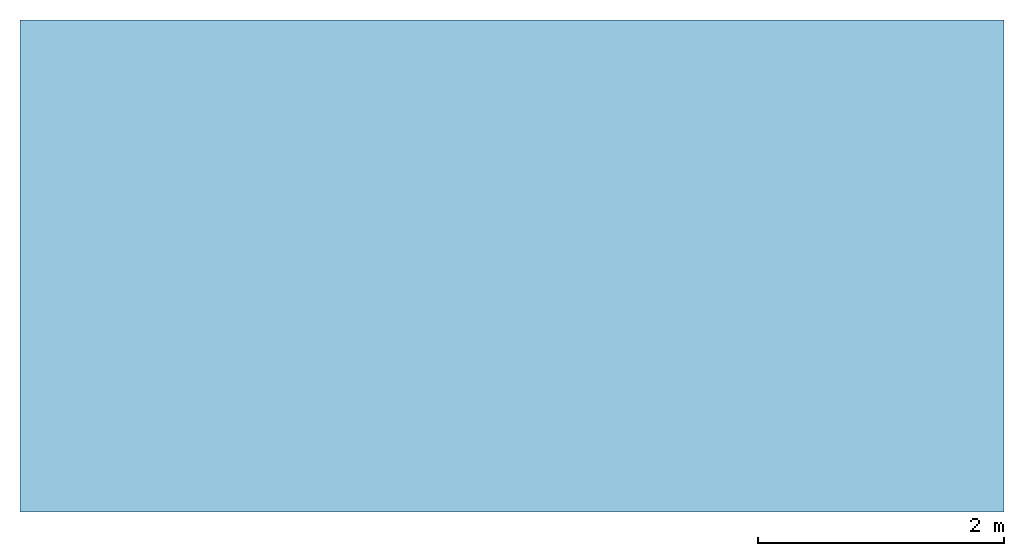
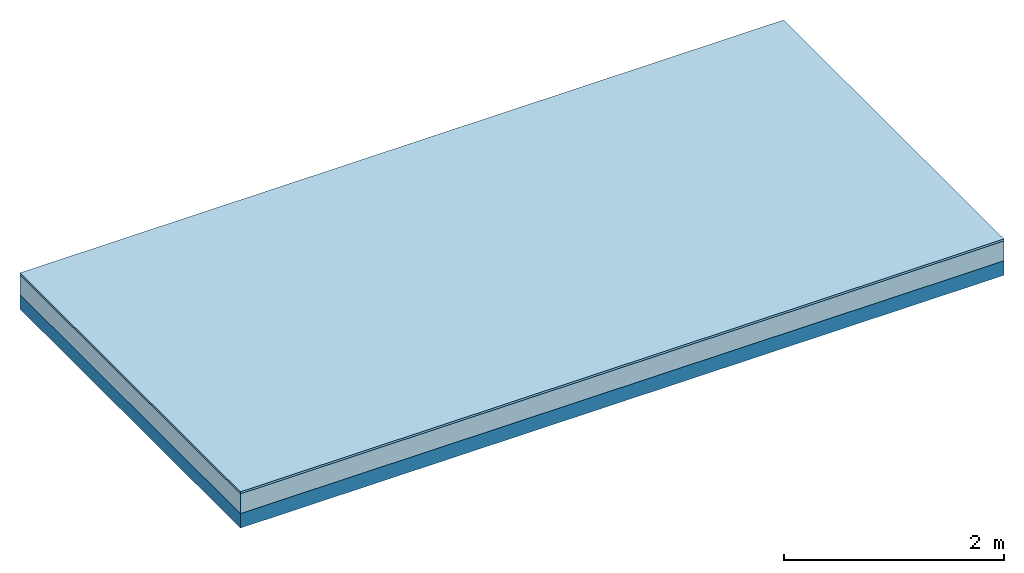
# One storey: 2 plates, 1 member, 1 element without a shape of its own.
"""IFC4 building model written with IfcOpenShell, lengths in metres."""

from ifc_helpers import new_model, si_unit, derived_unit, direction, frame, frame_2d, origin, origin_with_axes, place, context, project, spatial, rectangle, extrude, material, layer, layer_set, type_object, element, aggregate, save


model = new_model("IFC4")

# Units and contexts
plan_context = context("Plan", 3, precision=1e-05, world=origin(), true_north=direction((0.0, 1.0)))
model_context = context("Model", 3, precision=1e-05, world=origin(), true_north=direction((0.0, 1.0)))
ifc_project = project(units=[si_unit("LENGTHUNIT", "METRE"), derived_unit("SOUNDPRESSUREUNIT", [(si_unit("PRESSUREUNIT", "PASCAL", prefix="MICRO"), 0)]), si_unit("ENERGYUNIT", "JOULE", prefix="MEGA"), si_unit("MASSUNIT", "GRAM", prefix="KILO"), derived_unit("THERMALTRANSMITTANCEUNIT", [(si_unit("POWERUNIT", "WATT"), 1), (si_unit("AREAUNIT", "SQUARE_METRE"), -1), (si_unit("THERMODYNAMICTEMPERATUREUNIT", "KELVIN"), -1)]), derived_unit("AREADENSITYUNIT", [(si_unit("MASSUNIT", "GRAM", prefix="KILO"), 1), (si_unit("AREAUNIT", "SQUARE_METRE"), -1)]), derived_unit("USERDEFINED", [(si_unit("ENERGYUNIT", "JOULE", prefix="MEGA"), 1), (si_unit("AREAUNIT", "SQUARE_METRE"), -1)])], contexts=[plan_context, model_context])

# Site, building, storey
site = spatial("IfcSite", under=ifc_project)
building_placement = place(None, origin())
building = spatial("IfcBuilding", under=site, at=building_placement)
storey_placement = place(building_placement, origin())
storey = spatial("IfcBuildingStorey", under=building, at=storey_placement)

# Slab, member, plates
ifc_material_1 = material(Name="OSB3 panel", Category="07.013")
ifc_layer_1 = layer(ifc_material_1, 0.022, Name="On-material")
ifc_material_2 = material()
ifc_layer_2 = layer(ifc_material_2, 0.22, Name="Impact sound insulation")
ifc_material_3 = material(Name="no composite action")
ifc_layer_3 = layer(ifc_material_3, 0.0, Name="Bond")
ifc_layer_4 = layer(None, 0.16, Name="Supporting structure")
ifc_layer_set = layer_set([ifc_layer_1, ifc_layer_2, ifc_layer_3, ifc_layer_4])
slab_type = type_object("IfcSlabType", Name="A2178", PredefinedType="NOTDEFINED", material=ifc_layer_set)
slab_placement = place(None, frame((0.0, 0.0, 0.0), z_axis=(0.0, 0.0, -1.0), x_axis=(1.0, 0.0, 0.0)))
slab = element("IfcSlab", 1, at=slab_placement, inside=storey, type_object=slab_type, material=ifc_layer_set, Name="Slab #1")
ifc_material_4 = material(Name="Solid timber panel")
member_placement = place(slab_placement, origin())
member = element("IfcMember", 2, at=member_placement, material=ifc_material_4, Name="Supporting structure", context=plan_context, shape_type="SweptSolid", body=[
    extrude(rectangle(XDim=1.0, YDim=0.16, at=frame_2d((0.5, 0.08), x_axis=(1.0, 0.0))), frame((0.0, 4.0, 0.242), z_axis=(0.0, -1.0, 0.0), x_axis=(1.0, 0.0, 0.0)), (0.0, 0.0, 1.0), 4.0),
    extrude(rectangle(XDim=1.0, YDim=0.16, at=frame_2d((0.5, 0.08), x_axis=(1.0, 0.0))), frame((1.0, 4.0, 0.242), z_axis=(0.0, -1.0, 0.0), x_axis=(1.0, 0.0, 0.0)), (0.0, 0.0, 1.0), 4.0),
    extrude(rectangle(XDim=1.0, YDim=0.16, at=frame_2d((0.5, 0.08), x_axis=(1.0, 0.0))), frame((2.0, 4.0, 0.242), z_axis=(0.0, -1.0, 0.0), x_axis=(1.0, 0.0, 0.0)), (0.0, 0.0, 1.0), 4.0),
    extrude(rectangle(XDim=1.0, YDim=0.16, at=frame_2d((0.5, 0.08), x_axis=(1.0, 0.0))), frame((3.0, 4.0, 0.242), z_axis=(0.0, -1.0, 0.0), x_axis=(1.0, 0.0, 0.0)), (0.0, 0.0, 1.0), 4.0),
    extrude(rectangle(XDim=1.0, YDim=0.16, at=frame_2d((0.5, 0.08), x_axis=(1.0, 0.0))), frame((4.0, 4.0, 0.242), z_axis=(0.0, -1.0, 0.0), x_axis=(1.0, 0.0, 0.0)), (0.0, 0.0, 1.0), 4.0),
    extrude(rectangle(XDim=1.0, YDim=0.16, at=frame_2d((0.5, 0.08), x_axis=(1.0, 0.0))), frame((5.0, 4.0, 0.242), z_axis=(0.0, -1.0, 0.0), x_axis=(1.0, 0.0, 0.0)), (0.0, 0.0, 1.0), 4.0),
    extrude(rectangle(XDim=1.0, YDim=0.16, at=frame_2d((0.5, 0.08), x_axis=(1.0, 0.0))), frame((6.0, 4.0, 0.242), z_axis=(0.0, -1.0, 0.0), x_axis=(1.0, 0.0, 0.0)), (0.0, 0.0, 1.0), 4.0),
    extrude(rectangle(XDim=1.0, YDim=0.16, at=frame_2d((0.5, 0.08), x_axis=(1.0, 0.0))), frame((7.0, 4.0, 0.242), z_axis=(0.0, -1.0, 0.0), x_axis=(1.0, 0.0, 0.0)), (0.0, 0.0, 1.0), 4.0),
])
plate_1_placement = place(slab_placement, origin())
plate_1 = element("IfcPlate", 3, at=plate_1_placement, material=ifc_material_1, Name="On-material", context=plan_context, shape_type="SweptSolid", body=[
    extrude(rectangle(XDim=8.0, YDim=4.0, at=frame_2d((4.0, 2.0), x_axis=(1.0, 0.0))), origin_with_axes(), (0.0, 0.0, 1.0), 0.022),
])
plate_2_placement = place(slab_placement, origin())
plate_2 = element("IfcPlate", 4, at=plate_2_placement, material=ifc_material_2, Name="Impact sound insulation", context=plan_context, shape_type="SweptSolid", body=[
    extrude(rectangle(XDim=8.0, YDim=4.0, at=frame_2d((4.0, 2.0), x_axis=(1.0, 0.0))), frame((0.0, 0.0, 0.022), z_axis=(0.0, 0.0, 1.0), x_axis=(1.0, 0.0, 0.0)), (0.0, 0.0, 1.0), 0.22),
])
aggregate(slab, [plate_1, plate_2, member])

save(model, "model.ifc")
